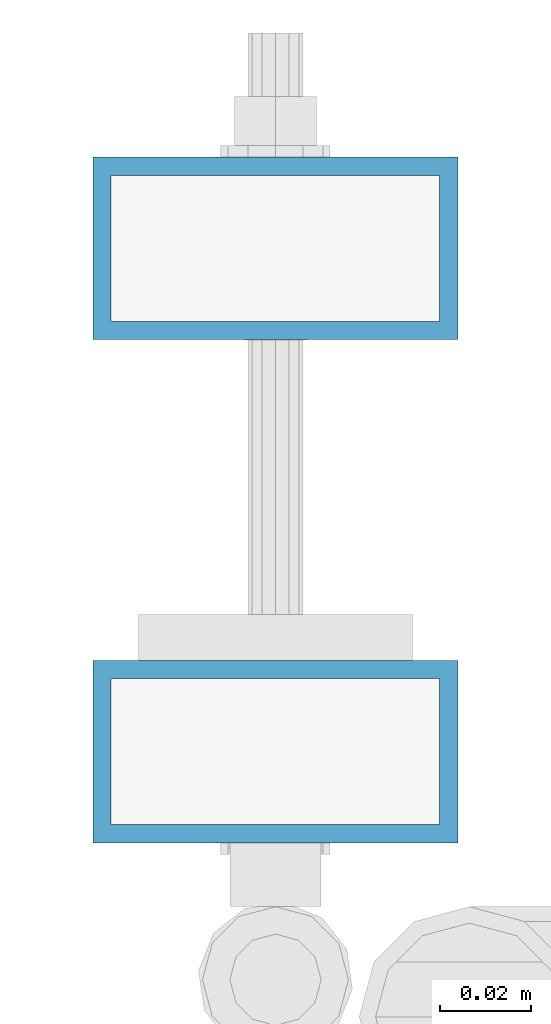
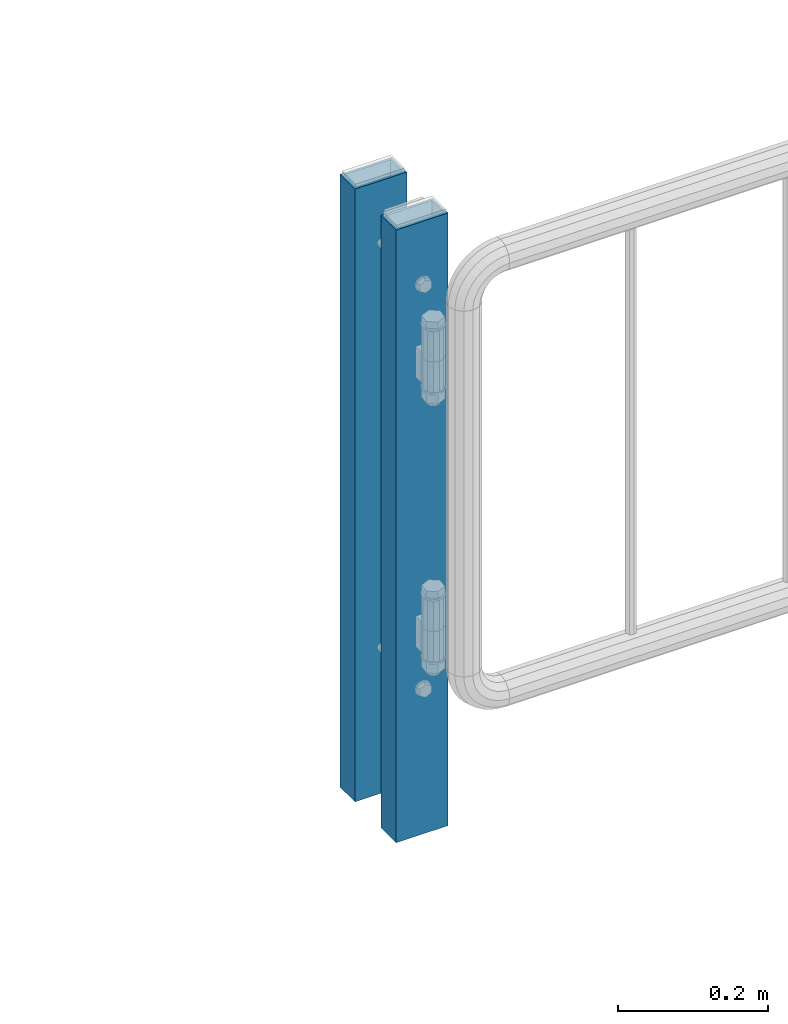
# One storey, part 67 of 247: 2 columns.
"""IFC2X3 building model written with IfcOpenShell, lengths in millimetres."""

from ifc_helpers import new_model, si_unit, frame, origin_with_axes, place, context, subcontext, project, spatial, faceted_brep, material, type_object, element, save


model = new_model("IFC2X3")

# Units and contexts
model_context = context("Model", 3, precision=1e-05, world=origin_with_axes())
body_context = subcontext(model_context, "Body", "Model", "MODEL_VIEW")
ifc_project = project(units=[si_unit("LENGTHUNIT", "METRE", prefix="MILLI"), si_unit("AREAUNIT", "SQUARE_METRE"), si_unit("VOLUMEUNIT", "CUBIC_METRE"), si_unit("MASSUNIT", "GRAM", prefix="KILO"), si_unit("TIMEUNIT", "SECOND"), si_unit("PLANEANGLEUNIT", "RADIAN"), si_unit("SOLIDANGLEUNIT", "STERADIAN"), si_unit("THERMODYNAMICTEMPERATUREUNIT", "DEGREE_CELSIUS"), si_unit("LUMINOUSINTENSITYUNIT", "LUMEN")], contexts=[model_context])

# Site, building, storey
site_placement = place(None, origin_with_axes())
site = spatial("IfcSite", under=ifc_project, at=site_placement, CompositionType="ELEMENT")
building_placement = place(site_placement, origin_with_axes())
building = spatial("IfcBuilding", under=site, at=building_placement, Name="Standard", CompositionType="ELEMENT")
storey_placement = place(building_placement, origin_with_axes())
storey = spatial("IfcBuildingStorey", under=building, at=storey_placement, Name="Undefined", CompositionType="ELEMENT", Elevation=0.0)

# Columns
ifc_material = material()
column_type = type_object("IfcColumnType", PredefinedType="NOTDEFINED")
for number, where, z_axis, x_axis in (
    (1, (26855.7462613762, 9110.30337247849, 6.54446186132418e-06), (-1.0, 0.0, 0.0), (0.0, 0.0, 1.0)),
    (2, (26855.7462613762, 9000.0033724785, 6.54446186132418e-06), (-1.0, 0.0, 0.0), (0.0, 0.0, 1.0)),
):
    element("IfcColumn", number, at=place(storey_placement, frame(where, z_axis=z_axis, x_axis=x_axis)), inside=storey, type_object=column_type, material=ifc_material, context=body_context, shape_type="Brep", body=[
        faceted_brep([(0.0, 16.0, -36.0), (0.0, -16.0, -36.0), (1000.0, -16.0, -36.0), (1000.0, 16.0, -36.0), (0.0, -16.0, 36.0), (1000.0, -16.0, 36.0), (0.0, 16.0, 36.0), (1000.0, 16.0, 36.0), (0.0, 20.0, -40.0), (0.0, 20.0, 40.0), (1000.0, 20.0, 40.0), (1000.0, 20.0, -40.0), (0.0, -20.0, 40.0), (1000.0, -20.0, 40.0), (0.0, -20.0, -40.0), (1000.0, -20.0, -40.0)], [[[0, 1, 2, 3]], [[1, 4, 5, 2]], [[4, 6, 7, 5]], [[6, 0, 3, 7]], [[8, 9, 10, 11]], [[9, 12, 13, 10]], [[12, 14, 15, 13]], [[14, 8, 11, 15]], [[13, 15, 11, 10], [5, 7, 3, 2]], [[14, 12, 9, 8], [6, 4, 1, 0]]]),
    ])

save(model, "model.ifc")
